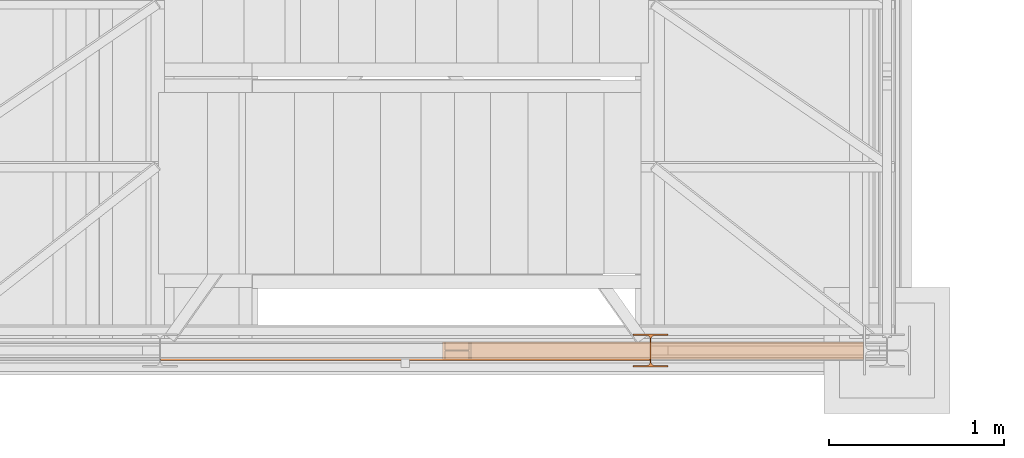
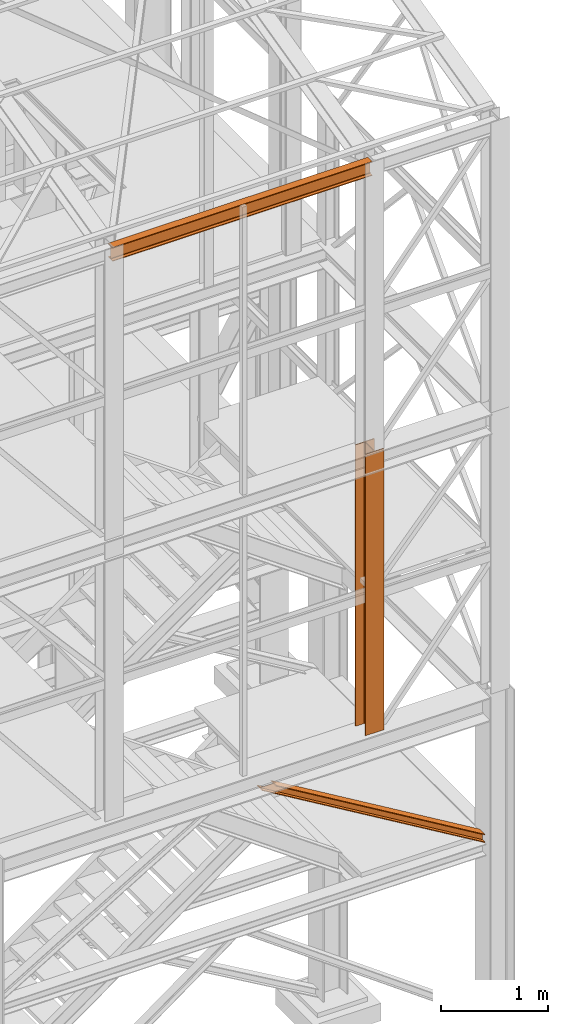
# One storey, part 43 of 208: 3 proxies.
"""IFC2X3 building model written with IfcOpenShell, lengths in millimetres."""

from ifc_helpers import new_model, entity, si_unit, converted_unit, frame, origin, origin_with_axes, place, context, subcontext, project, spatial, faceted_brep, element, save


model = new_model("IFC2X3")

# Units and contexts
model_context = context("Model", 3, precision=1e-05, world=origin())
plan_context = context("Plan", 3, precision=1e-05, world=origin())
body_context = subcontext(model_context, "Body", "Model", "MODEL_VIEW")
ifc_project = project(units=[si_unit("LENGTHUNIT", "METRE", prefix="MILLI"), converted_unit("PLANEANGLEUNIT", "DEGREE", entity("IfcPlaneAngleMeasure", 0.0174532925199433), si_unit("PLANEANGLEUNIT", "RADIAN"), dimensions=[0, 0, 0, 0, 0, 0, 0]), si_unit("AREAUNIT", "SQUARE_METRE"), si_unit("VOLUMEUNIT", "CUBIC_METRE")], contexts=[model_context, plan_context])

# Building, storey
building_placement = place(None, origin())
building = spatial("IfcBuilding", under=ifc_project, at=building_placement, CompositionType="COMPLEX")
storey_placement = place(building_placement, origin_with_axes())
storey = spatial("IfcBuildingStorey", under=building, at=storey_placement, Name="Geschoss", CompositionType="ELEMENT")

# Proxies
proxy_1_placement = place(storey_placement, frame((4160.397581067873, -25222.57439031789, 3580.490000221249), z_axis=(0.0, 0.0, 1.0), x_axis=(1.0, 0.0, 0.0)))
element("IfcBuildingElementProxy", 1, at=proxy_1_placement, inside=storey, context=body_context, shape_type="Brep", body=[
    faceted_brep([(2402.867382096373, 0.00999999999839929, 88.01000000000022), (2402.867382096373, 0.00999999999839929, 96.01000000000022), (2402.867382096373, 100.0099999999984, 96.01000000000022), (2402.867382096373, 100.0099999999984, 88.01000000000022), (2402.867382096373, 52.5099999999984, 88.01000000000022), (2402.867382096373, 52.5099999999984, 8.010000000000218), (2402.867382096373, 100.0099999999984, 8.010000000000218), (2402.867382096373, 100.0099999999984, 0.01000000000021828), (2402.867382096373, 0.00999999999839929, 0.01000000000021828), (2402.867382096373, 0.00999999999839929, 8.010000000000218), (2402.867382096373, 47.5099999999984, 8.010000000000218), (2402.867382096373, 47.5099999999984, 88.01000000000022), (2402.867382096373, 0.00999999999839929, 96.01000000000022), (2402.867382096373, 0.00999999999839929, 88.01000000000022), (150.5628293699992, 0.01000000000203727, 1434.509994414331), (164.2494502218169, 0.01000000000203727, 1434.509994414331), (2402.867382096373, 100.0099999999984, 96.01000000000022), (2402.867382096373, 0.00999999999839929, 96.01000000000022), (164.2494502218169, 0.01000000000203727, 1434.509994414331), (164.2494502218169, 100.010000000002, 1434.509994414331), (2402.867382096373, 100.0099999999984, 88.01000000000022), (2402.867382096373, 100.0099999999984, 96.01000000000022), (164.2494502218169, 100.010000000002, 1434.509994414331), (150.5628293699992, 100.0100000000057, 1434.509994414331), (2402.867382096373, 52.5099999999984, 88.01000000000022), (2402.867382096373, 100.0099999999984, 88.01000000000022), (150.5628293699992, 100.0100000000057, 1434.509994414331), (150.5628293699992, 52.51000000000204, 1434.509994414331), (2402.867382096373, 52.5099999999984, 8.010000000000218), (2402.867382096373, 52.5099999999984, 88.01000000000022), (150.5628293699992, 52.51000000000204, 1434.509994414331), (13.69662085181881, 52.51000000000568, 1434.509994414331), (2402.867382096373, 100.0099999999984, 8.010000000000218), (2402.867382096373, 52.5099999999984, 8.010000000000218), (13.69662085181881, 52.51000000000568, 1434.509994414331), (13.69662085181881, 100.010000000002, 1434.509994414331), (2402.867382096373, 100.0099999999984, 0.01000000000021828), (2402.867382096373, 100.0099999999984, 8.010000000000218), (13.69662085181881, 100.010000000002, 1434.509994414331), (0.01000000000021828, 100.0100000000057, 1434.509994414331), (2402.867382096373, 0.00999999999839929, 0.01000000000021828), (2402.867382096373, 100.0099999999984, 0.01000000000021828), (0.01000000000021828, 100.0100000000057, 1434.509994414331), (0.01000000000112777, 0.01000000000567525, 1434.509994414331), (2402.867382096373, 0.00999999999839929, 8.010000000000218), (2402.867382096373, 0.00999999999839929, 0.01000000000021828), (0.01000000000112777, 0.01000000000567525, 1434.509994414331), (13.69662085181881, 0.01000000000567525, 1434.509994414331), (2402.867382096373, 47.5099999999984, 8.010000000000218), (2402.867382096373, 0.00999999999839929, 8.010000000000218), (13.69662085181881, 0.01000000000567525, 1434.509994414331), (13.69662085181881, 47.51000000000204, 1434.509994414331), (2402.867382096373, 47.5099999999984, 88.01000000000022), (2402.867382096373, 47.5099999999984, 8.010000000000218), (13.69662085181881, 47.51000000000204, 1434.509994414331), (150.5628293699992, 47.51000000000204, 1434.509994414331), (2402.867382096373, 0.00999999999839929, 88.01000000000022), (2402.867382096373, 47.5099999999984, 88.01000000000022), (150.5628293699992, 47.51000000000204, 1434.509994414331), (150.5628293699992, 0.01000000000203727, 1434.509994414331), (150.5628293699992, 0.01000000000203727, 1434.509994414331), (150.5628293699992, 47.51000000000204, 1434.509994414331), (13.69662085181881, 47.51000000000204, 1434.509994414331), (13.69662085181881, 0.01000000000567525, 1434.509994414331), (0.01000000000112777, 0.01000000000567525, 1434.509994414331), (0.01000000000021828, 100.0100000000057, 1434.509994414331), (13.69662085181881, 100.010000000002, 1434.509994414331), (13.69662085181881, 52.51000000000568, 1434.509994414331), (150.5628293699992, 52.51000000000204, 1434.509994414331), (150.5628293699992, 100.0100000000057, 1434.509994414331), (164.2494502218169, 100.010000000002, 1434.509994414331), (164.2494502218169, 0.01000000000203727, 1434.509994414331)], [[[0, 1, 2, 3, 4, 5, 6, 7, 8, 9, 10, 11]], [[12, 13, 14, 15]], [[16, 17, 18, 19]], [[20, 21, 22, 23]], [[24, 25, 26, 27]], [[28, 29, 30, 31]], [[32, 33, 34, 35]], [[36, 37, 38, 39]], [[40, 41, 42, 43]], [[44, 45, 46, 47]], [[48, 49, 50, 51]], [[52, 53, 54, 55]], [[56, 57, 58, 59]], [[60, 61, 62, 63, 64, 65, 66, 67, 68, 69, 70, 71]]], orient=[[False], [False], [False], [False], [False], [False], [False], [False], [False], [False], [False], [False], [False], [False]]),
])
proxy_2_placement = place(storey_placement, frame((5248.25496703855, -25267.57438790133, 5284.990005364416), z_axis=(0.0, 0.0, 1.0), x_axis=(1.0, 0.0, 0.0)))
element("IfcBuildingElementProxy", 2, at=proxy_2_placement, inside=storey, context=body_context, shape_type="Brep", body=[
    faceted_brep([(0.01000000000021828, 190.0100125169738, 3200.009996721741), (200.0100029802325, 190.0100125169738, 3200.009996721741), (200.0100029802325, 180.0100146031364, 3200.009996721741), (121.2600035762789, 180.0100071525558, 3200.009996721741), (111.9441915473344, 178.1454621052726, 3200.009996721741), (105.1245498640838, 171.3258190250381, 3200.009996721741), (103.2600015571716, 162.0100079274162, 3200.009996721741), (103.2600015571716, 28.00999713897545, 3200.009996721741), (105.1245498640838, 18.69418604135353, 3200.009996721741), (111.9441915473344, 11.87454296111901, 3200.009996721741), (121.2600035762789, 10.00999791383583, 3200.009996721741), (200.0100029802325, 10.00999791383583, 3200.009996721741), (200.0100029802325, 0.00999999999839929, 3200.009996721741), (0.01000000000021828, 0.00999999999839929, 3200.009996721741), (0.01000000000021828, 10.00999791383583, 3200.009996721741), (78.75999940395377, 10.00999791383583, 3200.009996721741), (88.07581143289826, 11.87454296111901, 3200.009996721741), (94.89545311614893, 18.69418604135353, 3200.009996721741), (96.76000142306111, 28.00999713897545, 3200.009996721741), (96.76000142306111, 162.0100079274162, 3200.009996721741), (94.89545311614893, 171.3258190250381, 3200.009996721741), (88.07581143289826, 178.1454621052726, 3200.009996721741), (78.75999940395377, 180.0100071525558, 3200.009996721741), (0.01000000000021828, 180.0100146031364, 3200.009996721741), (200.0100029802325, 190.0100125169738, 3200.009996721741), (0.01000000000021828, 190.0100125169738, 3200.009996721741), (0.01000000000021828, 190.0100125169738, 0.009999999999308784), (200.0100029802325, 190.0100125169738, 0.009999999999308784), (200.0100029802325, 180.0100146031364, 3200.009996721741), (200.0100029802325, 190.0100125169738, 3200.009996721741), (200.0100029802325, 190.0100125169738, 0.009999999999308784), (200.0100029802325, 180.0100146031364, 0.009999999999308784), (121.2600035762789, 180.0100071525558, 3200.009996721741), (200.0100029802325, 180.0100146031364, 3200.009996721741), (200.0100029802325, 180.0100146031364, 0.009999999999308784), (121.2600035762789, 180.0100071525558, 0.009999999999308784), (111.9441915473344, 178.1454621052726, 3200.009996721741), (121.2600035762789, 180.0100071525558, 3200.009996721741), (121.2600035762789, 180.0100071525558, 0.009999999999308784), (111.9441915473344, 178.1454621052726, 0.009999999999308784), (105.1245498640838, 171.3258190250381, 3200.009996721741), (111.9441915473344, 178.1454621052726, 3200.009996721741), (111.9441915473344, 178.1454621052726, 0.009999999999308784), (105.1245498640838, 171.3258190250381, 0.009999999999308784), (103.2600015571716, 162.0100079274162, 3200.009996721741), (105.1245498640838, 171.3258190250381, 3200.009996721741), (105.1245498640838, 171.3258190250381, 0.009999999999308784), (103.2600015571716, 162.0100079274162, 0.009999999999308784), (103.2600015571716, 28.00999713897545, 3200.009996721741), (103.2600015571716, 162.0100079274162, 3200.009996721741), (103.2600015571716, 162.0100079274162, 0.009999999999308784), (103.2600015571716, 28.00999713897545, 0.009999999999308784), (105.1245498640838, 18.69418604135353, 3200.009996721741), (103.2600015571716, 28.00999713897545, 3200.009996721741), (103.2600015571716, 28.00999713897545, 0.009999999999308784), (105.1245498640838, 18.69418604135353, 0.009999999999308784), (111.9441915473344, 11.87454296111901, 3200.009996721741), (105.1245498640838, 18.69418604135353, 3200.009996721741), (105.1245498640838, 18.69418604135353, 0.009999999999308784), (111.9441915473344, 11.87454296111901, 0.009999999999308784), (121.2600035762789, 10.00999791383583, 3200.009996721741), (111.9441915473344, 11.87454296111901, 3200.009996721741), (111.9441915473344, 11.87454296111901, 0.009999999999308784), (121.2600035762789, 10.00999791383583, 0.009999999999308784), (200.0100029802325, 10.00999791383583, 3200.009996721741), (121.2600035762789, 10.00999791383583, 3200.009996721741), (121.2600035762789, 10.00999791383583, 0.009999999999308784), (200.0100029802325, 10.00999791383583, 0.009999999999308784), (200.0100029802325, 0.00999999999839929, 3200.009996721741), (200.0100029802325, 10.00999791383583, 3200.009996721741), (200.0100029802325, 10.00999791383583, 0.009999999999308784), (200.0100029802325, 0.00999999999839929, 0.009999999999308784), (0.01000000000021828, 0.00999999999839929, 3200.009996721741), (200.0100029802325, 0.00999999999839929, 3200.009996721741), (200.0100029802325, 0.00999999999839929, 0.009999999999308784), (0.01000000000021828, 0.00999999999839929, 0.009999999999308784), (0.01000000000021828, 10.00999791383583, 3200.009996721741), (0.01000000000021828, 0.00999999999839929, 3200.009996721741), (0.01000000000021828, 0.00999999999839929, 0.009999999999308784), (0.01000000000021828, 10.00999791383583, 0.009999999999308784), (78.75999940395377, 10.00999791383583, 3200.009996721741), (0.01000000000021828, 10.00999791383583, 3200.009996721741), (0.01000000000021828, 10.00999791383583, 0.009999999999308784), (78.75999940395377, 10.00999791383583, 0.009999999999308784), (88.07581143289826, 11.87454296111901, 3200.009996721741), (78.75999940395377, 10.00999791383583, 3200.009996721741), (78.75999940395377, 10.00999791383583, 0.009999999999308784), (88.07581143289826, 11.87454296111901, 0.009999999999308784), (94.89545311614893, 18.69418604135353, 3200.009996721741), (88.07581143289826, 11.87454296111901, 3200.009996721741), (88.07581143289826, 11.87454296111901, 0.009999999999308784), (94.89545311614893, 18.69418604135353, 0.009999999999308784), (96.76000142306111, 28.00999713897545, 3200.009996721741), (94.89545311614893, 18.69418604135353, 3200.009996721741), (94.89545311614893, 18.69418604135353, 0.009999999999308784), (96.76000142306111, 28.00999713897545, 0.009999999999308784), (96.76000142306111, 162.0100079274162, 3200.009996721741), (96.76000142306111, 28.00999713897545, 3200.009996721741), (96.76000142306111, 28.00999713897545, 0.009999999999308784), (96.76000142306111, 162.0100079274162, 0.009999999999308784), (94.89545311614893, 171.3258190250381, 3200.009996721741), (96.76000142306111, 162.0100079274162, 3200.009996721741), (96.76000142306111, 162.0100079274162, 0.009999999999308784), (94.89545311614893, 171.3258190250381, 0.009999999999308784), (88.07581143289826, 178.1454621052726, 3200.009996721741), (94.89545311614893, 171.3258190250381, 3200.009996721741), (94.89545311614893, 171.3258190250381, 0.009999999999308784), (88.07581143289826, 178.1454621052726, 0.009999999999308784), (78.75999940395377, 180.0100071525558, 3200.009996721741), (88.07581143289826, 178.1454621052726, 3200.009996721741), (88.07581143289826, 178.1454621052726, 0.009999999999308784), (78.75999940395377, 180.0100071525558, 0.009999999999308784), (0.01000000000021828, 180.0100146031364, 3200.009996721741), (78.75999940395377, 180.0100071525558, 3200.009996721741), (78.75999940395377, 180.0100071525558, 0.009999999999308784), (0.01000000000021828, 180.0100146031364, 0.009999999999308784), (0.01000000000021828, 190.0100125169738, 3200.009996721741), (0.01000000000021828, 180.0100146031364, 3200.009996721741), (0.01000000000021828, 180.0100146031364, 0.009999999999308784), (0.01000000000021828, 190.0100125169738, 0.009999999999308784), (0.01000000000021828, 190.0100125169738, 0.009999999999308784), (0.01000000000021828, 180.0100146031364, 0.009999999999308784), (78.75999940395377, 180.0100071525558, 0.009999999999308784), (88.07581143289826, 178.1454621052726, 0.009999999999308784), (94.89545311614893, 171.3258190250381, 0.009999999999308784), (96.76000142306111, 162.0100079274162, 0.009999999999308784), (96.76000142306111, 28.00999713897545, 0.009999999999308784), (94.89545311614893, 18.69418604135353, 0.009999999999308784), (88.07581143289826, 11.87454296111901, 0.009999999999308784), (78.75999940395377, 10.00999791383583, 0.009999999999308784), (0.01000000000021828, 10.00999791383583, 0.009999999999308784), (0.01000000000021828, 0.00999999999839929, 0.009999999999308784), (200.0100029802325, 0.00999999999839929, 0.009999999999308784), (200.0100029802325, 10.00999791383583, 0.009999999999308784), (121.2600035762789, 10.00999791383583, 0.009999999999308784), (111.9441915473344, 11.87454296111901, 0.009999999999308784), (105.1245498640838, 18.69418604135353, 0.009999999999308784), (103.2600015571716, 28.00999713897545, 0.009999999999308784), (103.2600015571716, 162.0100079274162, 0.009999999999308784), (105.1245498640838, 171.3258190250381, 0.009999999999308784), (111.9441915473344, 178.1454621052726, 0.009999999999308784), (121.2600035762789, 180.0100071525558, 0.009999999999308784), (200.0100029802325, 180.0100146031364, 0.009999999999308784), (200.0100029802325, 190.0100125169738, 0.009999999999308784)], [[[0, 1, 2, 3, 4, 5, 6, 7, 8, 9, 10, 11, 12, 13, 14, 15, 16, 17, 18, 19, 20, 21, 22, 23]], [[24, 25, 26, 27]], [[28, 29, 30, 31]], [[32, 33, 34, 35]], [[36, 37, 38, 39]], [[40, 41, 42, 43]], [[44, 45, 46, 47]], [[48, 49, 50, 51]], [[52, 53, 54, 55]], [[56, 57, 58, 59]], [[60, 61, 62, 63]], [[64, 65, 66, 67]], [[68, 69, 70, 71]], [[72, 73, 74, 75]], [[76, 77, 78, 79]], [[80, 81, 82, 83]], [[84, 85, 86, 87]], [[88, 89, 90, 91]], [[92, 93, 94, 95]], [[96, 97, 98, 99]], [[100, 101, 102, 103]], [[104, 105, 106, 107]], [[108, 109, 110, 111]], [[112, 113, 114, 115]], [[116, 117, 118, 119]], [[120, 121, 122, 123, 124, 125, 126, 127, 128, 129, 130, 131, 132, 133, 134, 135, 136, 137, 138, 139, 140, 141, 142, 143]]], orient=[[False], [False], [False], [False], [False], [False], [False], [False], [False], [False], [False], [False], [False], [False], [False], [False], [False], [False], [False], [False], [False], [False], [False], [False], [False], [False]]),
])
proxy_3_placement = place(storey_placement, frame((2551.504968595716, -25229.33296501014, 11599.98999433756), z_axis=(0.0, 0.0, 1.0), x_axis=(1.0, 0.0, 0.0)))
element("IfcBuildingElementProxy", 3, at=proxy_3_placement, inside=storey, context=body_context, shape_type="Brep", body=[
    faceted_brep([(2793.509999865887, 82.0100022649749, 0.01000000000021828), (2793.509999865888, 82.0100022649749, 7.40999860525335), (0.01000000000021828, 82.50957773438859, 7.409998605251531), (0.01000000000021828, 82.50957773438859, 0.01000000000021828), (2793.509999865888, 0.00999999999839929, 0.01000000000203727), (2793.509999865887, 82.0100022649749, 0.01000000000021828), (0.01000000000021828, 82.50957773438859, 0.01000000000021828), (0.01000000000021828, 0.5095754694120842, 0.01000000000021828), (2793.509999865888, 0.00999999999839929, 7.40999860525335), (2793.509999865888, 0.00999999999839929, 0.01000000000203727), (0.01000000000021828, 0.5095754694120842, 0.01000000000021828), (0.01000000000021828, 0.5095754694120842, 7.409998605251531), (2793.509999865887, 29.51000017881233, 7.409998605251531), (2793.509999865888, 0.00999999999839929, 7.40999860525335), (0.01000000000021828, 0.5095754694120842, 7.409998605251531), (0.01000000000021828, 30.00957564822602, 7.409998605251531), (2793.509999865887, 34.16790572762329, 8.342274854185234), (2793.509999865887, 29.51000017881233, 7.409998605251531), (0.01000000000021828, 30.00957564822602, 7.409998605251531), (0.01000000000021828, 34.66748119703698, 8.342274854185234), (2793.509999865888, 37.57772680207927, 11.7521001195928), (2793.509999865887, 34.16790572762329, 8.342274854185234), (0.01000000000021828, 34.66748119703698, 8.342274854185234), (0.01000000000021828, 38.07730227149295, 11.75210011959098), (2793.509999865888, 38.51000095553536, 16.41000194311346), (2793.509999865888, 37.57772680207927, 11.7521001195928), (0.01000000000021828, 38.07730227149295, 11.75210011959098), (0.01000000000021828, 39.00957642494905, 16.41000194311346), (2793.509999865888, 38.51000095553536, 143.6100093817731), (2793.509999865888, 38.51000095553536, 16.41000194311346), (0.01000000000021828, 39.00957642494905, 16.41000194311346), (0.01000000000021828, 39.00957642494905, 143.6100093817731), (2793.509999865887, 37.57772680207927, 148.2679112052938), (2793.509999865888, 38.51000095553536, 143.6100093817731), (0.01000000000021828, 39.00957642494905, 143.6100093817731), (0.01000000000021828, 38.07730227149295, 148.2679112052938), (2793.509999865888, 34.16790572762329, 151.6777364707014), (2793.509999865887, 37.57772680207927, 148.2679112052938), (0.01000000000021828, 38.07730227149295, 148.2679112052938), (0.01000000000021828, 34.66748119703698, 151.6777364707014), (2793.509999865888, 29.51000017881233, 152.6100127196332), (2793.509999865888, 34.16790572762329, 151.6777364707014), (0.01000000000021828, 34.66748119703698, 151.6777364707014), (0.01000000000021828, 30.00957564822602, 152.6100127196332), (2793.509999865888, 0.00999999999839929, 152.6100127196332), (2793.509999865888, 29.51000017881233, 152.6100127196332), (0.01000000000021828, 30.00957564822602, 152.6100127196332), (0.01000000000021828, 0.5095754694120842, 152.6100127196332), (2793.509999865888, 0.00999999999839929, 160.0100113248845), (2793.509999865888, 0.00999999999839929, 152.6100127196332), (0.01000000000021828, 0.5095754694120842, 152.6100127196332), (0.01000000000021828, 0.5095754694120842, 160.0100113248845), (2793.509999865887, 82.0100022649749, 160.0100113248845), (2793.509999865888, 0.00999999999839929, 160.0100113248845), (0.01000000000021828, 0.5095754694120842, 160.0100113248845), (0.01000000000021828, 82.50957773438859, 160.0100113248845), (2793.509999865887, 82.0100022649749, 152.6100127196332), (2793.509999865887, 82.0100022649749, 160.0100113248845), (0.01000000000021828, 82.50957773438859, 160.0100113248845), (0.01000000000021828, 82.50957773438859, 152.6100127196332), (2793.509999865888, 52.51000208616097, 152.6100127196332), (2793.509999865887, 82.0100022649749, 152.6100127196332), (0.01000000000021828, 82.50957773438859, 152.6100127196332), (0.01000000000021828, 53.00957755557465, 152.6100127196332), (2793.509999865888, 47.85209653735001, 151.6777364707014), (2793.509999865888, 52.51000208616097, 152.6100127196332), (0.01000000000021828, 53.00957755557465, 152.6100127196332), (0.01000000000021828, 48.35167200676369, 151.6777364707014), (2793.509999865888, 44.44227546289403, 148.2679112052938), (2793.509999865888, 47.85209653735001, 151.6777364707014), (0.01000000000021828, 48.35167200676369, 151.6777364707014), (0.01000000000112777, 44.94185093230772, 148.2679112052938), (2793.509999865887, 43.51000130943794, 143.6100093817731), (2793.509999865888, 44.44227546289403, 148.2679112052938), (0.01000000000112777, 44.94185093230772, 148.2679112052938), (0.01000000000021828, 44.00957677885162, 143.6100093817731), (2793.509999865887, 43.51000130943794, 16.41000194311346), (2793.509999865887, 43.51000130943794, 143.6100093817731), (0.01000000000021828, 44.00957677885162, 143.6100093817731), (0.01000000000021828, 44.00957677885162, 16.41000194311346), (2793.509999865887, 44.44227546289403, 11.7521001195928), (2793.509999865887, 43.51000130943794, 16.41000194311346), (0.01000000000021828, 44.00957677885162, 16.41000194311346), (0.01000000000021828, 44.94185093230772, 11.7521001195928), (2793.509999865887, 47.85209653735001, 8.342274854185234), (2793.509999865887, 44.44227546289403, 11.7521001195928), (0.01000000000021828, 44.94185093230772, 11.7521001195928), (0.01000000000021828, 48.35167200676369, 8.342274854185234), (2793.509999865887, 52.51000208616097, 7.409998605251531), (2793.509999865887, 47.85209653735001, 8.342274854185234), (0.01000000000021828, 48.35167200676369, 8.342274854185234), (0.01000000000021828, 53.00957755557465, 7.409998605251531), (2793.509999865888, 82.0100022649749, 7.40999860525335), (2793.509999865887, 52.51000208616097, 7.409998605251531), (0.01000000000021828, 53.00957755557465, 7.409998605251531), (0.01000000000021828, 82.50957773438859, 7.409998605251531), (0.01000000000021828, 82.50957773438859, 7.409998605251531), (0.01000000000021828, 53.00957755557465, 7.409998605251531), (0.01000000000021828, 48.35167200676369, 8.342274854185234), (0.01000000000021828, 44.94185093230772, 11.7521001195928), (0.01000000000021828, 44.00957677885162, 16.41000194311346), (0.01000000000021828, 44.00957677885162, 143.6100093817731), (0.01000000000112777, 44.94185093230772, 148.2679112052938), (0.01000000000021828, 48.35167200676369, 151.6777364707014), (0.01000000000021828, 53.00957755557465, 152.6100127196332), (0.01000000000021828, 82.50957773438859, 152.6100127196332), (0.01000000000021828, 82.50957773438859, 160.0100113248845), (0.01000000000021828, 0.5095754694120842, 160.0100113248845), (0.01000000000021828, 0.5095754694120842, 152.6100127196332), (0.01000000000021828, 30.00957564822602, 152.6100127196332), (0.01000000000021828, 34.66748119703698, 151.6777364707014), (0.01000000000021828, 38.07730227149295, 148.2679112052938), (0.01000000000021828, 39.00957642494905, 143.6100093817731), (0.01000000000021828, 39.00957642494905, 16.41000194311346), (0.01000000000021828, 38.07730227149295, 11.75210011959098), (0.01000000000021828, 34.66748119703698, 8.342274854185234), (0.01000000000021828, 30.00957564822602, 7.409998605251531), (0.01000000000021828, 0.5095754694120842, 7.409998605251531), (0.01000000000021828, 0.5095754694120842, 0.01000000000021828), (0.01000000000021828, 82.50957773438859, 0.01000000000021828), (2793.509999865887, 82.0100022649749, 0.01000000000021828), (2793.509999865888, 0.00999999999839929, 0.01000000000203727), (2793.509999865888, 0.00999999999839929, 7.40999860525335), (2793.509999865887, 29.51000017881233, 7.409998605251531), (2793.509999865887, 34.16790572762329, 8.342274854185234), (2793.509999865888, 37.57772680207927, 11.7521001195928), (2793.509999865888, 38.51000095553536, 16.41000194311346), (2793.509999865888, 38.51000095553536, 143.6100093817731), (2793.509999865887, 37.57772680207927, 148.2679112052938), (2793.509999865888, 34.16790572762329, 151.6777364707014), (2793.509999865888, 29.51000017881233, 152.6100127196332), (2793.509999865888, 0.00999999999839929, 152.6100127196332), (2793.509999865888, 0.00999999999839929, 160.0100113248845), (2793.509999865887, 82.0100022649749, 160.0100113248845), (2793.509999865887, 82.0100022649749, 152.6100127196332), (2793.509999865888, 52.51000208616097, 152.6100127196332), (2793.509999865888, 47.85209653735001, 151.6777364707014), (2793.509999865888, 44.44227546289403, 148.2679112052938), (2793.509999865887, 43.51000130943794, 143.6100093817731), (2793.509999865887, 43.51000130943794, 16.41000194311346), (2793.509999865887, 44.44227546289403, 11.7521001195928), (2793.509999865887, 47.85209653735001, 8.342274854185234), (2793.509999865887, 52.51000208616097, 7.409998605251531), (2793.509999865888, 82.0100022649749, 7.40999860525335)], [[[0, 1, 2, 3]], [[4, 5, 6, 7]], [[8, 9, 10, 11]], [[12, 13, 14, 15]], [[16, 17, 18, 19]], [[20, 21, 22, 23]], [[24, 25, 26, 27]], [[28, 29, 30, 31]], [[32, 33, 34, 35]], [[36, 37, 38, 39]], [[40, 41, 42, 43]], [[44, 45, 46, 47]], [[48, 49, 50, 51]], [[52, 53, 54, 55]], [[56, 57, 58, 59]], [[60, 61, 62, 63]], [[64, 65, 66, 67]], [[68, 69, 70, 71]], [[72, 73, 74, 75]], [[76, 77, 78, 79]], [[80, 81, 82, 83]], [[84, 85, 86, 87]], [[88, 89, 90, 91]], [[92, 93, 94, 95]], [[96, 97, 98, 99, 100, 101, 102, 103, 104, 105, 106, 107, 108, 109, 110, 111, 112, 113, 114, 115, 116, 117, 118, 119]], [[120, 121, 122, 123, 124, 125, 126, 127, 128, 129, 130, 131, 132, 133, 134, 135, 136, 137, 138, 139, 140, 141, 142, 143]]], orient=[[False], [False], [False], [False], [False], [False], [False], [False], [False], [False], [False], [False], [False], [False], [False], [False], [False], [False], [False], [False], [False], [False], [False], [False], [False], [False]]),
])

save(model, "model.ifc")
